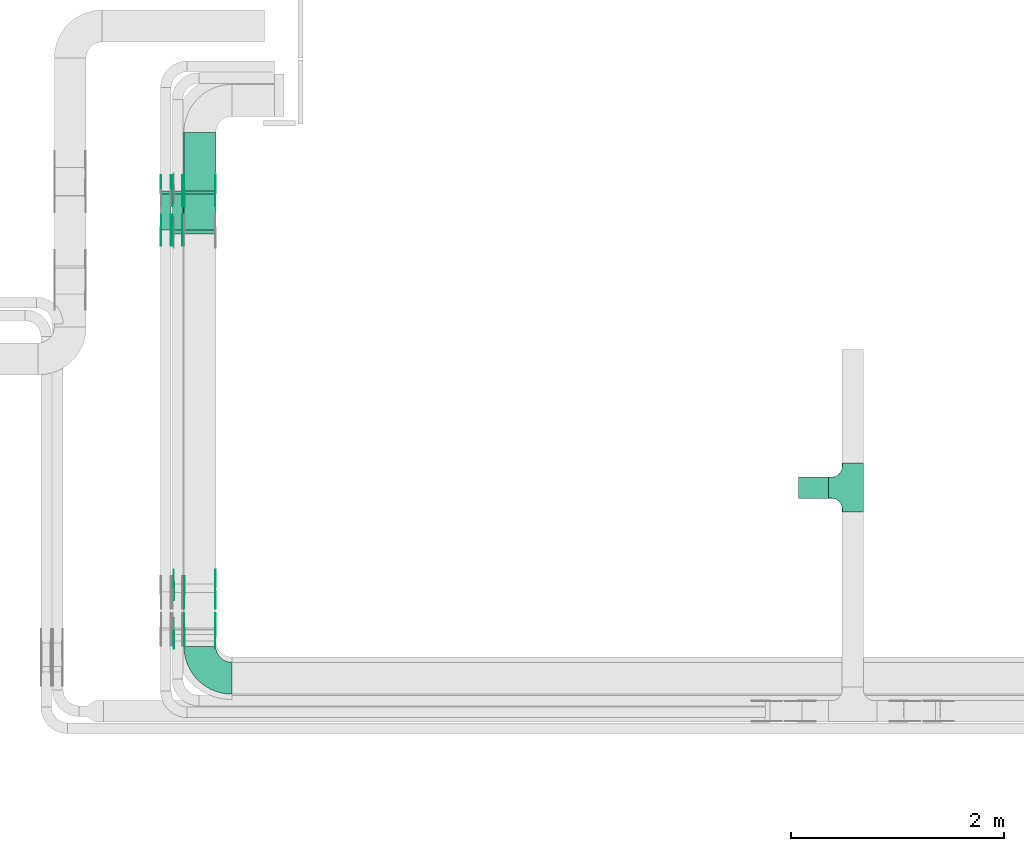
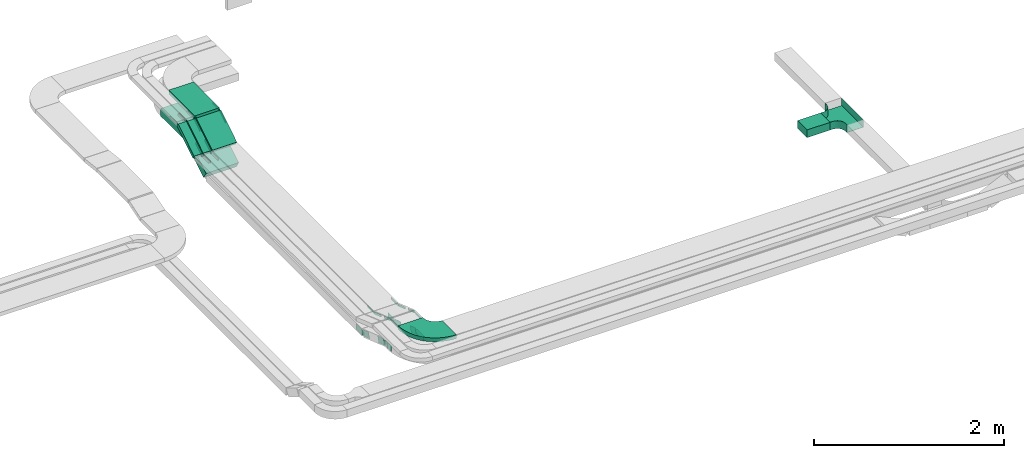
# One storey, part 7 of 27: 36 flow fittings, 7 flow segments.
"""IFC2X3 building model written with IfcOpenShell, lengths in millimetres."""

from ifc_helpers import new_model, entity, si_unit, converted_unit, derived_unit, direction, frame, frame_2d, origin, origin_2d_with_axis, place, context, subcontext, project, spatial, polyline, circle_curve, parameter, trimmed, segment, composite_curve, rectangle, outline, extrude, faceted_brep, source, transform, mapped, material, type_object, type_shapes, element, save


model = new_model("IFC2X3")

# Units and contexts
model_context = context("Model", 3, precision=0.01, world=origin(), true_north=direction((6.12303176911189e-17, 1.0)))
body_context = subcontext(model_context, "Body", "Model", "MODEL_VIEW")
ifc_project = project(units=[si_unit("LENGTHUNIT", "METRE", prefix="MILLI"), si_unit("AREAUNIT", "SQUARE_METRE"), si_unit("VOLUMEUNIT", "CUBIC_METRE"), converted_unit("PLANEANGLEUNIT", "DEGREE", entity("IfcRatioMeasure", 0.0174532925199433), si_unit("PLANEANGLEUNIT", "RADIAN"), dimensions=[0, 0, 0, 0, 0, 0, 0]), si_unit("MASSUNIT", "GRAM", prefix="KILO"), derived_unit("MASSDENSITYUNIT", [(si_unit("MASSUNIT", "GRAM", prefix="KILO"), 1), (si_unit("LENGTHUNIT", "METRE"), -3)]), derived_unit("MOMENTOFINERTIAUNIT", [(si_unit("LENGTHUNIT", "METRE"), 4)]), si_unit("TIMEUNIT", "SECOND"), si_unit("FREQUENCYUNIT", "HERTZ"), si_unit("THERMODYNAMICTEMPERATUREUNIT", "DEGREE_CELSIUS"), derived_unit("THERMALTRANSMITTANCEUNIT", [(si_unit("MASSUNIT", "GRAM", prefix="KILO"), 1), (si_unit("THERMODYNAMICTEMPERATUREUNIT", "KELVIN"), -1), (si_unit("TIMEUNIT", "SECOND"), -3)]), derived_unit("VOLUMETRICFLOWRATEUNIT", [(si_unit("LENGTHUNIT", "METRE"), 3), (si_unit("TIMEUNIT", "SECOND"), -1)]), derived_unit("MASSFLOWRATEUNIT", [(si_unit("MASSUNIT", "GRAM", prefix="KILO"), 1), (si_unit("TIMEUNIT", "SECOND"), -1)]), derived_unit("ROTATIONALFREQUENCYUNIT", [(si_unit("TIMEUNIT", "SECOND"), -1)]), si_unit("ELECTRICCURRENTUNIT", "AMPERE"), si_unit("ELECTRICVOLTAGEUNIT", "VOLT"), si_unit("POWERUNIT", "WATT"), si_unit("FORCEUNIT", "NEWTON", prefix="KILO"), si_unit("ILLUMINANCEUNIT", "LUX"), si_unit("LUMINOUSFLUXUNIT", "LUMEN"), si_unit("LUMINOUSINTENSITYUNIT", "CANDELA"), derived_unit("USERDEFINED", [(si_unit("MASSUNIT", "GRAM", prefix="KILO"), -1), (si_unit("LENGTHUNIT", "METRE"), -2), (si_unit("TIMEUNIT", "SECOND"), 3), (si_unit("LUMINOUSFLUXUNIT", "LUMEN"), 1)]), derived_unit("LINEARVELOCITYUNIT", [(si_unit("LENGTHUNIT", "METRE"), 1), (si_unit("TIMEUNIT", "SECOND"), -1)]), si_unit("PRESSUREUNIT", "PASCAL"), derived_unit("USERDEFINED", [(si_unit("LENGTHUNIT", "METRE"), -2), (si_unit("MASSUNIT", "GRAM", prefix="KILO"), 1), (si_unit("TIMEUNIT", "SECOND"), -2)]), derived_unit("LINEARFORCEUNIT", [(si_unit("MASSUNIT", "GRAM", prefix="KILO"), 1), (si_unit("LENGTHUNIT", "METRE"), 1), (si_unit("TIMEUNIT", "SECOND"), -2), (si_unit("LENGTHUNIT", "METRE"), -1)]), derived_unit("PLANARFORCEUNIT", [(si_unit("MASSUNIT", "GRAM", prefix="KILO"), 1), (si_unit("LENGTHUNIT", "METRE"), 1), (si_unit("TIMEUNIT", "SECOND"), -2), (si_unit("LENGTHUNIT", "METRE"), -2)])], contexts=[model_context])

# Site, building, storey
site_placement = place(None, origin())
site = spatial("IfcSite", under=ifc_project, at=site_placement, CompositionType="ELEMENT")
building_placement = place(site_placement, origin())
building = spatial("IfcBuilding", under=site, at=building_placement, CompositionType="ELEMENT")
storey_placement = place(building_placement, origin())
storey = spatial("IfcBuildingStorey", under=building, at=storey_placement, CompositionType="ELEMENT", Elevation=0.0)

# Flow segments
cable_carrier_segment_type = type_object("IfcCableCarrierSegmentType", PredefinedType="CABLETRAYSEGMENT")
flow_segment_1_placement = place(storey_placement, frame((21183.6, 10463.36, 2950.0)))
element("IfcFlowSegment", 1, at=flow_segment_1_placement, inside=storey, type_object=cable_carrier_segment_type, context=body_context, shape_type="SweptSolid", body=[
    extrude(rectangle(XDim=280.000000000001, YDim=200.000000000002, at=origin_2d_with_axis()), frame((140.0, 100.0, 0.0), z_axis=(0.0, 0.0, 1.0), x_axis=(-1.0, 0.0, 0.0)), (0.0, 0.0, 1.0), 100.0),
])
flow_segment_2_placement = place(storey_placement, frame((15400.0, 12989.83, 3238.74)))
element("IfcFlowSegment", 2, at=flow_segment_2_placement, inside=storey, type_object=cable_carrier_segment_type, context=body_context, shape_type="SweptSolid", body=[
    extrude(rectangle(XDim=50.000000000001, YDim=396.526348882561, at=frame_2d((0.0, 0.0), x_axis=(0.0, 1.0))), frame((0.0, 181.38, 126.26), z_axis=(1.0, 0.0, 0.0), x_axis=(0.0, 0.848048096156902, 0.529919264232443)), (0.0, 0.0, 1.0), 300.000000000001),
])
flow_segment_3_placement = place(storey_placement, frame((15300.0, 12948.55, 2956.33)))
element("IfcFlowSegment", 3, at=flow_segment_3_placement, inside=storey, type_object=cable_carrier_segment_type, context=body_context, shape_type="SweptSolid", body=[
    extrude(rectangle(XDim=99.9999999999987, YDim=457.672276185984, at=frame_2d((0.0, 0.0), x_axis=(0.0, 1.0))), frame((0.0, 220.56, 163.67), z_axis=(1.0, 0.0, 0.0), x_axis=(0.0, 0.848048096156363, 0.529919264233306)), (0.0, 0.0, 1.0), 400.0),
])
flow_segment_4_placement = place(storey_placement, frame((15290.0, 12989.83, 3238.74)))
element("IfcFlowSegment", 4, at=flow_segment_4_placement, inside=storey, type_object=cable_carrier_segment_type, context=body_context, shape_type="SweptSolid", body=[
    extrude(rectangle(XDim=49.9999999999982, YDim=396.526348877707, at=frame_2d((0.0, 0.0), x_axis=(0.0, 1.0))), frame((0.0, 181.38, 126.26), z_axis=(1.0, 0.0, 0.0), x_axis=(0.0, 0.848048096157075, 0.529919264232167)), (0.0, 0.0, 1.0), 99.9999999999967),
])
flow_segment_5_placement = place(storey_placement, frame((15180.0, 12989.83, 3238.74)))
element("IfcFlowSegment", 5, at=flow_segment_5_placement, inside=storey, type_object=cable_carrier_segment_type, context=body_context, shape_type="SweptSolid", body=[
    extrude(rectangle(XDim=49.9999999999994, YDim=396.526348877544, at=frame_2d((0.0, 0.0), x_axis=(0.0, 1.0))), frame((0.0, 181.38, 126.26), z_axis=(1.0, 0.0, 0.0), x_axis=(0.0, 0.848048096156966, 0.529919264232341)), (0.0, 0.0, 1.0), 99.9999999999989),
])
flow_segment_6_placement = place(storey_placement, frame((15400.0, 13356.57, 3450.0)))
element("IfcFlowSegment", 6, at=flow_segment_6_placement, inside=storey, type_object=cable_carrier_segment_type, context=body_context, shape_type="SweptSolid", body=[
    extrude(rectangle(XDim=549.993317234229, YDim=300.000000000001, at=origin_2d_with_axis()), frame((150.0, 275.0, 0.0), z_axis=(0.0, 0.0, 1.0), x_axis=(0.0, 1.0, 0.0)), (0.0, 0.0, 1.0), 49.9999999999995),
])
flow_segment_7_placement = place(storey_placement, frame((15300.0, 13393.64, 3200.0)))
element("IfcFlowSegment", 7, at=flow_segment_7_placement, inside=storey, type_object=cable_carrier_segment_type, context=body_context, shape_type="SweptSolid", body=[
    extrude(rectangle(XDim=512.924514815445, YDim=400.0, at=origin_2d_with_axis()), frame((200.0, 256.46, 0.0), z_axis=(0.0, 0.0, 1.0), x_axis=(0.0, -1.0, 0.0)), (0.0, 0.0, 1.0), 99.9999999999995),
])

# Flow fittings
ifc_material_1 = material()
cable_carrier_fitting_type_1 = type_object("IfcCableCarrierFittingType", PredefinedType="NOTDEFINED", material=ifc_material_1)
shared_shape_1 = source(origin(), body_context, "Body", "Brep", [
    faceted_brep([(-103.41, -174.12, 50.0), (-100.0, -200.0, 50.0), (-100.0, -230.0, 50.0), (-99.2, -230.0, 50.0), (-99.2, -200.0, 50.0), (-102.63, -173.91, 50.0), (-112.7, -149.6, 50.0), (-128.72, -128.72, 50.0), (-149.6, -112.7, 50.0), (-173.91, -102.63, 50.0), (-200.0, -99.2, 50.0), (-230.0, -99.2, 50.0), (-230.0, -100.0, 50.0), (-200.0, -100.0, 50.0), (-174.12, -103.41, 50.0), (-150.0, -113.4, 50.0), (-129.29, -129.29, 50.0), (-113.4, -150.0, 50.0), (230.0, -100.0, 50.0), (230.0, -99.2, 50.0), (200.0, -99.2, 50.0), (173.91, -102.63, 50.0), (149.6, -112.7, 50.0), (128.72, -128.72, 50.0), (112.7, -149.6, 50.0), (102.63, -173.91, 50.0), (99.2, -200.0, 50.0), (99.2, -230.0, 50.0), (100.0, -230.0, 50.0), (100.0, -200.0, 50.0), (103.41, -174.12, 50.0), (113.4, -150.0, 50.0), (129.29, -129.29, 50.0), (150.0, -113.4, 50.0), (174.12, -103.41, 50.0), (200.0, -100.0, 50.0), (230.0, 99.2, 50.0), (230.0, 100.0, 50.0), (-230.0, 100.0, 50.0), (-230.0, 99.2, 50.0), (-230.0, -100.0, -50.0), (-230.0, 100.0, -50.0), (230.0, 100.0, -50.0), (230.0, -100.0, -50.0), (200.0, -100.0, -50.0), (174.12, -103.41, -50.0), (150.0, -113.4, -50.0), (129.29, -129.29, -50.0), (113.4, -150.0, -50.0), (103.41, -174.12, -50.0), (100.0, -200.0, -50.0), (100.0, -230.0, -50.0), (-100.0, -230.0, -50.0), (-100.0, -200.0, -50.0), (-103.41, -174.12, -50.0), (-113.4, -150.0, -50.0), (-129.29, -129.29, -50.0), (-150.0, -113.4, -50.0), (-174.12, -103.41, -50.0), (-200.0, -100.0, -50.0), (-100.0, -200.0, -49.2), (99.2, -230.0, -49.2), (-99.2, -230.0, -49.2), (-99.2, -200.0, -49.2), (-200.0, -99.2, -49.2), (-230.0, -99.2, -49.2), (230.0, -99.2, -49.2), (200.0, -99.2, -49.2), (-230.0, 99.2, -49.2), (-200.0, -100.0, -49.2), (200.0, -100.0, -49.2), (230.0, 99.2, -49.2), (99.2, -200.0, -49.2), (100.0, -200.0, -49.2), (-173.91, -102.63, -49.2), (-149.6, -112.7, -49.2), (-128.72, -128.72, -49.2), (-112.7, -149.6, -49.2), (-102.63, -173.91, -49.2), (102.63, -173.91, -49.2), (112.7, -149.6, -49.2), (128.72, -128.72, -49.2), (149.6, -112.7, -49.2), (173.91, -102.63, -49.2)], [[[0, 1, 2, 3, 4, 5, 6, 7, 8, 9, 10, 11, 12, 13, 14, 15, 16, 17]], [[18, 19, 20, 21, 22, 23, 24, 25, 26, 27, 28, 29, 30, 31, 32, 33, 34, 35]], [[36, 37, 38, 39]], [[40, 41, 42, 43, 44, 45, 46, 47, 48, 49, 50, 51, 52, 53, 54, 55, 56, 57, 58, 59]], [[2, 1, 60, 53, 52]], [[3, 2, 52, 51, 28, 27, 61, 62]], [[4, 3, 62, 63]], [[11, 10, 64, 65]], [[20, 19, 66, 67]], [[39, 38, 41, 40, 12, 11, 65, 68]], [[13, 12, 40, 59, 69]], [[18, 35, 70, 44, 43]], [[19, 18, 43, 42, 37, 36, 71, 66]], [[27, 26, 72, 61]], [[29, 28, 51, 50, 73]], [[38, 37, 42, 41]], [[36, 39, 68, 71]], [[68, 65, 64, 74, 75, 76, 77, 78, 63, 62, 61, 72, 79, 80, 81, 82, 83, 67, 66, 71]], [[14, 13, 69, 59, 58]], [[15, 14, 58, 57]], [[57, 56, 16, 15]], [[17, 16, 56, 55]], [[0, 17, 55, 54]], [[1, 0, 54, 53, 60]], [[5, 78, 77, 6]], [[6, 77, 76, 7]], [[63, 78, 5, 4]], [[8, 75, 74, 9]], [[9, 74, 64, 10]], [[7, 76, 75, 8]], [[21, 83, 82, 22]], [[22, 82, 81, 23]], [[67, 83, 21, 20]], [[24, 80, 79, 25]], [[25, 79, 72, 26]], [[23, 81, 80, 24]], [[30, 29, 73, 50, 49]], [[31, 30, 49, 48]], [[32, 31, 48, 47]], [[34, 33, 46, 45]], [[34, 45, 44, 70, 35]], [[46, 33, 32, 47]]]),
])
type_shapes(cable_carrier_fitting_type_1, [shared_shape_1])
flow_fitting_1_placement = place(storey_placement, frame((21693.6, 10563.36, 3000.0), z_axis=(0.0, 0.0, 1.0), x_axis=(0.0, -1.0, 0.0)))
element("IfcFlowFitting", 8, at=flow_fitting_1_placement, inside=storey, type_object=cable_carrier_fitting_type_1, material=ifc_material_1, Name="470_DKC_S5_T", context=body_context, shape_type="MappedRepresentation", body=[
    mapped(shared_shape_1, transform((0.0, 0.0, 0.0), scale=1.0)),
])
cable_carrier_fitting_type_2 = type_object("IfcCableCarrierFittingType", Name="470_DKC_S5_Variable Angle Elbow 0-45:-", PredefinedType="NOTDEFINED", material=ifc_material_1)
shared_shape_2 = source(origin(), body_context, "Body", "SweptSolid", [
    extrude(outline(composite_curve([segment(polyline([(-150.75, -300.25), (-149.75, -300.25)]), True, "CONTINUOUS"), segment(trimmed(circle_curve(frame_2d((-149.75, 149.75), x_axis=(0.0, -1.0)), 450.0), [parameter(0.0)], [parameter(90.0000000000001)], True, "PARAMETER"), True, "CONTINUOUS"), segment(polyline([(300.25, 149.75), (300.25, 150.75)]), True, "CONTINUOUS"), segment(polyline([(300.25, 150.75), (0.25, 150.75)]), True, "CONTINUOUS"), segment(polyline([(0.25, 150.75), (0.25, 149.75)]), True, "CONTINUOUS"), segment(trimmed(circle_curve(frame_2d((-149.75, 149.75), x_axis=(0.0, -1.0)), 150.0), [parameter(0.0)], [parameter(90.0000000000001)], True, "PARAMETER"), False, "CONTINUOUS"), segment(polyline([(-149.75, -0.25), (-150.75, -0.25)]), True, "CONTINUOUS"), segment(polyline([(-150.75, -0.25), (-150.75, -300.25)]), True, "CONTINUOUS")], self_intersect=False)), frame((-150.25, 150.25, -25.0)), (0.0, 0.0, 1.0), 49.9999999999974),
])
type_shapes(cable_carrier_fitting_type_2, [shared_shape_2])
flow_fitting_2_placement = place(storey_placement, frame((15550.0, 8770.0, 3375.0), z_axis=(0.0, 0.0, 1.0), x_axis=(0.0, -1.0, 0.0)))
element("IfcFlowFitting", 9, at=flow_fitting_2_placement, inside=storey, type_object=cable_carrier_fitting_type_2, material=ifc_material_1, Name="470_DKC_S5_Variable Angle Elbow 0-45:-", ObjectType="470_DKC_S5_Variable Angle Elbow 0-45:-", context=body_context, shape_type="MappedRepresentation", body=[
    mapped(shared_shape_2, transform((0.0, 0.0, 0.0), scale=1.0)),
])
ifc_material_2 = material(Name="G")
cable_carrier_fitting_type_3 = type_object("IfcCableCarrierFittingType", PredefinedType="NOTDEFINED", material=ifc_material_2)
shared_shape_3 = source(origin(), body_context, "Body", "SweptSolid", [
    extrude(outline(composite_curve([segment(trimmed(circle_curve(frame_2d((-44.59, 0.0), x_axis=(1.0, 0.0)), 12.5), [parameter(90.0000000000007)], [parameter(270.0)], True, "PARAMETER"), True, "CONTINUOUS"), segment(polyline([(-44.59, -12.5), (-33.09, -12.5)]), True, "CONTINUOUS"), segment(polyline([(-33.09, -12.5), (-31.23, -14.5)]), True, "CONTINUOUS"), segment(polyline([(-31.23, -14.5), (108.91, -14.5)]), True, "CONTINUOUS"), segment(polyline([(108.91, -14.5), (108.91, 14.5)]), True, "CONTINUOUS"), segment(polyline([(108.91, 14.5), (-31.23, 14.5)]), True, "CONTINUOUS"), segment(polyline([(-31.23, 14.5), (-33.09, 12.5)]), True, "CONTINUOUS"), segment(polyline([(-33.09, 12.5), (-44.59, 12.5)]), True, "CONTINUOUS")], self_intersect=False)), frame((44.59, 0.0, 0.0), z_axis=(0.0, 0.0, -1.0), x_axis=(1.0, 0.0, 0.0)), (0.0, 0.0, -1.0), 2.0),
])
type_shapes(cable_carrier_fitting_type_3, [shared_shape_3])
flow_fitting_3_placement = place(storey_placement, frame((15404.54, 13347.25, 3475.0), z_axis=(-1.0, 0.0, 0.0), x_axis=(0.0, 1.0, 0.0)))
element("IfcFlowFitting", 10, at=flow_fitting_3_placement, inside=storey, type_object=cable_carrier_fitting_type_3, material=ifc_material_2, context=body_context, shape_type="MappedRepresentation", body=[
    mapped(shared_shape_3, transform((0.0, 0.0, 0.0), scale=1.0)),
])
cable_carrier_fitting_type_4 = type_object("IfcCableCarrierFittingType", PredefinedType="NOTDEFINED", material=ifc_material_2)
type_shapes(cable_carrier_fitting_type_4, [shared_shape_3])
flow_fitting_4_placement = place(storey_placement, frame((15693.46, 13347.25, 3475.0), z_axis=(1.0, 0.0, 0.0), x_axis=(0.0, -0.848048096156421, -0.529919264233212)))
element("IfcFlowFitting", 11, at=flow_fitting_4_placement, inside=storey, type_object=cable_carrier_fitting_type_4, material=ifc_material_2, context=body_context, shape_type="MappedRepresentation", body=[
    mapped(shared_shape_3, transform((0.0, 0.0, 0.0), scale=1.0)),
])
flow_fitting_5_placement = place(storey_placement, frame((15294.54, 12995.18, 3255.0), z_axis=(-1.0, 0.0, 0.0), x_axis=(0.0, -1.0, 0.0)))
element("IfcFlowFitting", 12, at=flow_fitting_5_placement, inside=storey, type_object=cable_carrier_fitting_type_3, material=ifc_material_2, context=body_context, shape_type="MappedRepresentation", body=[
    mapped(shared_shape_3, transform((0.0, 0.0, 0.0), scale=1.0)),
])
flow_fitting_6_placement = place(storey_placement, frame((15383.46, 12995.18, 3255.0), z_axis=(1.0, 0.0, 0.0), x_axis=(0.0, 0.848048096157054, 0.529919264232201)))
element("IfcFlowFitting", 13, at=flow_fitting_6_placement, inside=storey, type_object=cable_carrier_fitting_type_4, material=ifc_material_2, context=body_context, shape_type="MappedRepresentation", body=[
    mapped(shared_shape_3, transform((0.0, 0.0, 0.0), scale=1.0)),
])
flow_fitting_7_placement = place(storey_placement, frame((15184.54, 12995.18, 3255.0), z_axis=(-1.0, 0.0, 0.0), x_axis=(0.0, -1.0, 0.0)))
element("IfcFlowFitting", 14, at=flow_fitting_7_placement, inside=storey, type_object=cable_carrier_fitting_type_3, material=ifc_material_2, context=body_context, shape_type="MappedRepresentation", body=[
    mapped(shared_shape_3, transform((0.0, 0.0, 0.0), scale=1.0)),
])
flow_fitting_8_placement = place(storey_placement, frame((15273.46, 12995.18, 3255.0), z_axis=(1.0, 0.0, 0.0), x_axis=(0.0, 0.848048096156942, 0.529919264232379)))
element("IfcFlowFitting", 15, at=flow_fitting_8_placement, inside=storey, type_object=cable_carrier_fitting_type_4, material=ifc_material_2, context=body_context, shape_type="MappedRepresentation", body=[
    mapped(shared_shape_3, transform((0.0, 0.0, 0.0), scale=1.0)),
])
flow_fitting_9_placement = place(storey_placement, frame((15294.54, 13347.25, 3475.0), z_axis=(-1.0, 0.0, 0.0), x_axis=(0.0, 1.0, 0.0)))
element("IfcFlowFitting", 16, at=flow_fitting_9_placement, inside=storey, type_object=cable_carrier_fitting_type_3, material=ifc_material_2, context=body_context, shape_type="MappedRepresentation", body=[
    mapped(shared_shape_3, transform((0.0, 0.0, 0.0), scale=1.0)),
])
flow_fitting_10_placement = place(storey_placement, frame((15383.46, 13347.25, 3475.0), z_axis=(1.0, 0.0, 0.0), x_axis=(0.0, -0.848048096157089, -0.529919264232144)))
element("IfcFlowFitting", 17, at=flow_fitting_10_placement, inside=storey, type_object=cable_carrier_fitting_type_4, material=ifc_material_2, context=body_context, shape_type="MappedRepresentation", body=[
    mapped(shared_shape_3, transform((0.0, 0.0, 0.0), scale=1.0)),
])
for number, where, z_axis, x_axis in (
    (18, (15184.54, 13347.25, 3475.0), (-1.0, 0.0, 0.0), (0.0, 1.0, 0.0)),
    (19, (15404.54, 9230.0, 3375.0), (-1.0, 0.0, 0.0), (0.0, 0.944549723773494, -0.328368420100679)),
):
    element("IfcFlowFitting", number, at=place(storey_placement, frame(where, z_axis=z_axis, x_axis=x_axis)), inside=storey, type_object=cable_carrier_fitting_type_3, material=ifc_material_2, context=body_context, shape_type="MappedRepresentation", body=[
        mapped(shared_shape_3, transform((0.0, 0.0, 0.0), scale=1.0)),
    ])
flow_fitting_11_placement = place(storey_placement, frame((15693.46, 9230.0, 3375.0), z_axis=(1.0, 0.0, 0.0), x_axis=(0.0, -1.0, 0.0)))
element("IfcFlowFitting", 20, at=flow_fitting_11_placement, inside=storey, type_object=cable_carrier_fitting_type_4, material=ifc_material_2, context=body_context, shape_type="MappedRepresentation", body=[
    mapped(shared_shape_3, transform((0.0, 0.0, 0.0), scale=1.0)),
])
flow_fitting_12_placement = place(storey_placement, frame((15404.54, 9575.18, 3255.0), z_axis=(-1.0, 0.0, 0.0), x_axis=(0.0, -0.944549723773494, 0.328368420100679)))
element("IfcFlowFitting", 21, at=flow_fitting_12_placement, inside=storey, type_object=cable_carrier_fitting_type_3, material=ifc_material_2, context=body_context, shape_type="MappedRepresentation", body=[
    mapped(shared_shape_3, transform((0.0, 0.0, 0.0), scale=1.0)),
])
flow_fitting_13_placement = place(storey_placement, frame((15693.46, 9575.18, 3255.0), z_axis=(1.0, 0.0, 0.0), x_axis=(0.0, 1.0, 0.0)))
element("IfcFlowFitting", 22, at=flow_fitting_13_placement, inside=storey, type_object=cable_carrier_fitting_type_4, material=ifc_material_2, context=body_context, shape_type="MappedRepresentation", body=[
    mapped(shared_shape_3, transform((0.0, 0.0, 0.0), scale=1.0)),
])
cable_carrier_fitting_type_5 = type_object("IfcCableCarrierFittingType", PredefinedType="NOTDEFINED", material=ifc_material_2)
shared_shape_4 = source(origin(), body_context, "Body", "SweptSolid", [
    extrude(outline(composite_curve([segment(trimmed(circle_curve(frame_2d((-44.59, 0.0), x_axis=(1.0, 0.0)), 12.5), [parameter(90.0000000000007)], [parameter(270.0)], True, "PARAMETER"), True, "CONTINUOUS"), segment(polyline([(-44.59, -12.5), (-33.09, -12.5)]), True, "CONTINUOUS"), segment(polyline([(-33.09, -12.5), (-31.23, -14.5)]), True, "CONTINUOUS"), segment(polyline([(-31.23, -14.5), (108.91, -14.5)]), True, "CONTINUOUS"), segment(polyline([(108.91, -14.5), (108.91, 14.5)]), True, "CONTINUOUS"), segment(polyline([(108.91, 14.5), (-31.23, 14.5)]), True, "CONTINUOUS"), segment(polyline([(-31.23, 14.5), (-33.09, 12.5)]), True, "CONTINUOUS"), segment(polyline([(-33.09, 12.5), (-44.59, 12.5)]), True, "CONTINUOUS")], self_intersect=False)), frame((44.59, 0.0, 0.0)), (0.0, 0.0, 1.0), 2.0),
])
type_shapes(cable_carrier_fitting_type_5, [shared_shape_4])
flow_fitting_14_placement = place(storey_placement, frame((15695.46, 13347.25, 3475.0), z_axis=(1.0, 0.0, 0.0), x_axis=(0.0, 1.0, 0.0)))
element("IfcFlowFitting", 23, at=flow_fitting_14_placement, inside=storey, type_object=cable_carrier_fitting_type_5, material=ifc_material_2, context=body_context, shape_type="MappedRepresentation", body=[
    mapped(shared_shape_4, transform((0.0, 0.0, 0.0), scale=1.0)),
])
cable_carrier_fitting_type_6 = type_object("IfcCableCarrierFittingType", PredefinedType="NOTDEFINED", material=ifc_material_2)
type_shapes(cable_carrier_fitting_type_6, [shared_shape_4])
flow_fitting_15_placement = place(storey_placement, frame((15406.54, 13347.25, 3475.0), z_axis=(-1.0, 0.0, 0.0), x_axis=(0.0, -0.848048096156421, -0.529919264233212)))
element("IfcFlowFitting", 24, at=flow_fitting_15_placement, inside=storey, type_object=cable_carrier_fitting_type_6, material=ifc_material_2, context=body_context, shape_type="MappedRepresentation", body=[
    mapped(shared_shape_4, transform((0.0, 0.0, 0.0), scale=1.0)),
])
flow_fitting_16_placement = place(storey_placement, frame((15385.46, 12995.18, 3255.0), z_axis=(1.0, 0.0, 0.0), x_axis=(0.0, -1.0, 0.0)))
element("IfcFlowFitting", 25, at=flow_fitting_16_placement, inside=storey, type_object=cable_carrier_fitting_type_5, material=ifc_material_2, context=body_context, shape_type="MappedRepresentation", body=[
    mapped(shared_shape_4, transform((0.0, 0.0, 0.0), scale=1.0)),
])
flow_fitting_17_placement = place(storey_placement, frame((15296.54, 12995.18, 3255.0), z_axis=(-1.0, 0.0, 0.0), x_axis=(0.0, 0.848048096157054, 0.529919264232201)))
element("IfcFlowFitting", 26, at=flow_fitting_17_placement, inside=storey, type_object=cable_carrier_fitting_type_6, material=ifc_material_2, context=body_context, shape_type="MappedRepresentation", body=[
    mapped(shared_shape_4, transform((0.0, 0.0, 0.0), scale=1.0)),
])
flow_fitting_18_placement = place(storey_placement, frame((15275.46, 12995.18, 3255.0), z_axis=(1.0, 0.0, 0.0), x_axis=(0.0, -1.0, 0.0)))
element("IfcFlowFitting", 27, at=flow_fitting_18_placement, inside=storey, type_object=cable_carrier_fitting_type_5, material=ifc_material_2, context=body_context, shape_type="MappedRepresentation", body=[
    mapped(shared_shape_4, transform((0.0, 0.0, 0.0), scale=1.0)),
])
flow_fitting_19_placement = place(storey_placement, frame((15186.54, 12995.18, 3255.0), z_axis=(-1.0, 0.0, 0.0), x_axis=(0.0, 0.848048096156942, 0.529919264232379)))
element("IfcFlowFitting", 28, at=flow_fitting_19_placement, inside=storey, type_object=cable_carrier_fitting_type_6, material=ifc_material_2, context=body_context, shape_type="MappedRepresentation", body=[
    mapped(shared_shape_4, transform((0.0, 0.0, 0.0), scale=1.0)),
])
flow_fitting_20_placement = place(storey_placement, frame((15385.46, 13347.25, 3475.0), z_axis=(1.0, 0.0, 0.0), x_axis=(0.0, 1.0, 0.0)))
element("IfcFlowFitting", 29, at=flow_fitting_20_placement, inside=storey, type_object=cable_carrier_fitting_type_5, material=ifc_material_2, context=body_context, shape_type="MappedRepresentation", body=[
    mapped(shared_shape_4, transform((0.0, 0.0, 0.0), scale=1.0)),
])
flow_fitting_21_placement = place(storey_placement, frame((15296.54, 13347.25, 3475.0), z_axis=(-1.0, 0.0, 0.0), x_axis=(0.0, -0.848048096157089, -0.529919264232144)))
element("IfcFlowFitting", 30, at=flow_fitting_21_placement, inside=storey, type_object=cable_carrier_fitting_type_6, material=ifc_material_2, context=body_context, shape_type="MappedRepresentation", body=[
    mapped(shared_shape_4, transform((0.0, 0.0, 0.0), scale=1.0)),
])
for number, where, z_axis, x_axis in (
    (31, (15275.46, 13347.25, 3475.0), (1.0, 0.0, 0.0), (0.0, 1.0, 0.0)),
    (32, (15695.46, 9230.0, 3375.0), (1.0, 0.0, 0.0), (0.0, 0.944549723773494, -0.328368420100679)),
):
    element("IfcFlowFitting", number, at=place(storey_placement, frame(where, z_axis=z_axis, x_axis=x_axis)), inside=storey, type_object=cable_carrier_fitting_type_5, material=ifc_material_2, context=body_context, shape_type="MappedRepresentation", body=[
        mapped(shared_shape_4, transform((0.0, 0.0, 0.0), scale=1.0)),
    ])
flow_fitting_22_placement = place(storey_placement, frame((15406.54, 9230.0, 3375.0), z_axis=(-1.0, 0.0, 0.0), x_axis=(0.0, -1.0, 0.0)))
element("IfcFlowFitting", 33, at=flow_fitting_22_placement, inside=storey, type_object=cable_carrier_fitting_type_6, material=ifc_material_2, context=body_context, shape_type="MappedRepresentation", body=[
    mapped(shared_shape_4, transform((0.0, 0.0, 0.0), scale=1.0)),
])
flow_fitting_23_placement = place(storey_placement, frame((15695.46, 9575.18, 3255.0), z_axis=(1.0, 0.0, 0.0), x_axis=(0.0, -0.944549723773494, 0.328368420100679)))
element("IfcFlowFitting", 34, at=flow_fitting_23_placement, inside=storey, type_object=cable_carrier_fitting_type_5, material=ifc_material_2, context=body_context, shape_type="MappedRepresentation", body=[
    mapped(shared_shape_4, transform((0.0, 0.0, 0.0), scale=1.0)),
])
flow_fitting_24_placement = place(storey_placement, frame((15406.54, 9575.18, 3255.0), z_axis=(-1.0, 0.0, 0.0), x_axis=(0.0, 1.0, 0.0)))
element("IfcFlowFitting", 35, at=flow_fitting_24_placement, inside=storey, type_object=cable_carrier_fitting_type_6, material=ifc_material_2, context=body_context, shape_type="MappedRepresentation", body=[
    mapped(shared_shape_4, transform((0.0, 0.0, 0.0), scale=1.0)),
])
cable_carrier_fitting_type_7 = type_object("IfcCableCarrierFittingType", PredefinedType="NOTDEFINED", material=ifc_material_2)
shared_shape_5 = source(origin(), body_context, "Body", "SweptSolid", [
    extrude(outline(composite_curve([segment(trimmed(circle_curve(frame_2d((-41.47, 0.0), x_axis=(1.0, 0.0)), 25.0), [parameter(90.0000000000007)], [parameter(270.0)], True, "PARAMETER"), True, "CONTINUOUS"), segment(polyline([(-41.47, -25.0), (-29.97, -25.0)]), True, "CONTINUOUS"), segment(polyline([(-29.97, -25.0), (-28.1, -38.5)]), True, "CONTINUOUS"), segment(polyline([(-28.1, -38.5), (99.53, -38.5)]), True, "CONTINUOUS"), segment(polyline([(99.53, -38.5), (99.53, 38.5)]), True, "CONTINUOUS"), segment(polyline([(99.53, 38.5), (-28.1, 38.5)]), True, "CONTINUOUS"), segment(polyline([(-28.1, 38.5), (-29.97, 25.0)]), True, "CONTINUOUS"), segment(polyline([(-29.97, 25.0), (-41.47, 25.0)]), True, "CONTINUOUS")], self_intersect=False)), frame((41.47, 0.0, 0.0), z_axis=(0.0, 0.0, -1.0), x_axis=(1.0, 0.0, 0.0)), (0.0, 0.0, -1.0), 2.0),
])
type_shapes(cable_carrier_fitting_type_7, [shared_shape_5])
flow_fitting_25_placement = place(storey_placement, frame((15304.54, 9190.0, 3150.0), z_axis=(-1.0, 0.0, 0.0), x_axis=(0.0, 0.944549723773443, -0.328368420100826)))
element("IfcFlowFitting", 36, at=flow_fitting_25_placement, inside=storey, type_object=cable_carrier_fitting_type_7, material=ifc_material_2, context=body_context, shape_type="MappedRepresentation", body=[
    mapped(shared_shape_5, transform((0.0, 0.0, 0.0), scale=1.0)),
])
cable_carrier_fitting_type_8 = type_object("IfcCableCarrierFittingType", PredefinedType="NOTDEFINED", material=ifc_material_2)
type_shapes(cable_carrier_fitting_type_8, [shared_shape_5])
flow_fitting_26_placement = place(storey_placement, frame((15693.46, 9190.0, 3150.0), z_axis=(1.0, 0.0, 0.0), x_axis=(0.0, -1.0, 0.0)))
element("IfcFlowFitting", 37, at=flow_fitting_26_placement, inside=storey, type_object=cable_carrier_fitting_type_8, material=ifc_material_2, context=body_context, shape_type="MappedRepresentation", body=[
    mapped(shared_shape_5, transform((0.0, 0.0, 0.0), scale=1.0)),
])
flow_fitting_27_placement = place(storey_placement, frame((15695.46, 9650.24, 2990.0), z_axis=(1.0, 0.0, 0.0), x_axis=(0.0, 1.0, 0.0)))
element("IfcFlowFitting", 38, at=flow_fitting_27_placement, inside=storey, type_object=cable_carrier_fitting_type_7, material=ifc_material_2, context=body_context, shape_type="MappedRepresentation", body=[
    mapped(shared_shape_5, transform((0.0, 0.0, 0.0), scale=1.0)),
])
flow_fitting_28_placement = place(storey_placement, frame((15306.54, 9650.24, 2990.0), z_axis=(-1.0, 0.0, 0.0), x_axis=(0.0, -0.94454972377344, 0.328368420100834)))
element("IfcFlowFitting", 39, at=flow_fitting_28_placement, inside=storey, type_object=cable_carrier_fitting_type_8, material=ifc_material_2, context=body_context, shape_type="MappedRepresentation", body=[
    mapped(shared_shape_5, transform((0.0, 0.0, 0.0), scale=1.0)),
])
cable_carrier_fitting_type_9 = type_object("IfcCableCarrierFittingType", PredefinedType="NOTDEFINED", material=ifc_material_2)
shared_shape_6 = source(origin(), body_context, "Body", "SweptSolid", [
    extrude(outline(composite_curve([segment(trimmed(circle_curve(frame_2d((-41.47, 0.0), x_axis=(1.0, 0.0)), 25.0), [parameter(90.0000000000007)], [parameter(270.0)], True, "PARAMETER"), True, "CONTINUOUS"), segment(polyline([(-41.47, -25.0), (-29.97, -25.0)]), True, "CONTINUOUS"), segment(polyline([(-29.97, -25.0), (-28.1, -38.5)]), True, "CONTINUOUS"), segment(polyline([(-28.1, -38.5), (99.53, -38.5)]), True, "CONTINUOUS"), segment(polyline([(99.53, -38.5), (99.53, 38.5)]), True, "CONTINUOUS"), segment(polyline([(99.53, 38.5), (-28.1, 38.5)]), True, "CONTINUOUS"), segment(polyline([(-28.1, 38.5), (-29.97, 25.0)]), True, "CONTINUOUS"), segment(polyline([(-29.97, 25.0), (-41.47, 25.0)]), True, "CONTINUOUS")], self_intersect=False)), frame((41.47, 0.0, 0.0)), (0.0, 0.0, 1.0), 2.0),
])
type_shapes(cable_carrier_fitting_type_9, [shared_shape_6])
flow_fitting_29_placement = place(storey_placement, frame((15695.46, 9190.0, 3150.0), z_axis=(1.0, 0.0, 0.0), x_axis=(0.0, 0.944549723773443, -0.328368420100826)))
element("IfcFlowFitting", 40, at=flow_fitting_29_placement, inside=storey, type_object=cable_carrier_fitting_type_9, material=ifc_material_2, context=body_context, shape_type="MappedRepresentation", body=[
    mapped(shared_shape_6, transform((0.0, 0.0, 0.0), scale=1.0)),
])
cable_carrier_fitting_type_10 = type_object("IfcCableCarrierFittingType", PredefinedType="NOTDEFINED", material=ifc_material_2)
type_shapes(cable_carrier_fitting_type_10, [shared_shape_6])
flow_fitting_30_placement = place(storey_placement, frame((15306.54, 9190.0, 3150.0), z_axis=(-1.0, 0.0, 0.0), x_axis=(0.0, -1.0, 0.0)))
element("IfcFlowFitting", 41, at=flow_fitting_30_placement, inside=storey, type_object=cable_carrier_fitting_type_10, material=ifc_material_2, context=body_context, shape_type="MappedRepresentation", body=[
    mapped(shared_shape_6, transform((0.0, 0.0, 0.0), scale=1.0)),
])
flow_fitting_31_placement = place(storey_placement, frame((15304.54, 9650.24, 2990.0), z_axis=(-1.0, 0.0, 0.0), x_axis=(0.0, 1.0, 0.0)))
element("IfcFlowFitting", 42, at=flow_fitting_31_placement, inside=storey, type_object=cable_carrier_fitting_type_9, material=ifc_material_2, context=body_context, shape_type="MappedRepresentation", body=[
    mapped(shared_shape_6, transform((0.0, 0.0, 0.0), scale=1.0)),
])
flow_fitting_32_placement = place(storey_placement, frame((15693.46, 9650.24, 2990.0), z_axis=(1.0, 0.0, 0.0), x_axis=(0.0, -0.94454972377344, 0.328368420100834)))
element("IfcFlowFitting", 43, at=flow_fitting_32_placement, inside=storey, type_object=cable_carrier_fitting_type_10, material=ifc_material_2, context=body_context, shape_type="MappedRepresentation", body=[
    mapped(shared_shape_6, transform((0.0, 0.0, 0.0), scale=1.0)),
])

save(model, "model.ifc")
